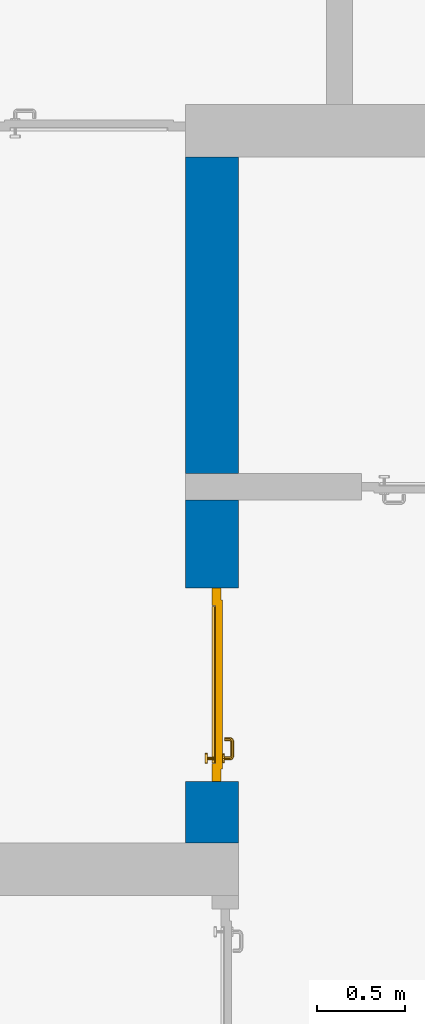
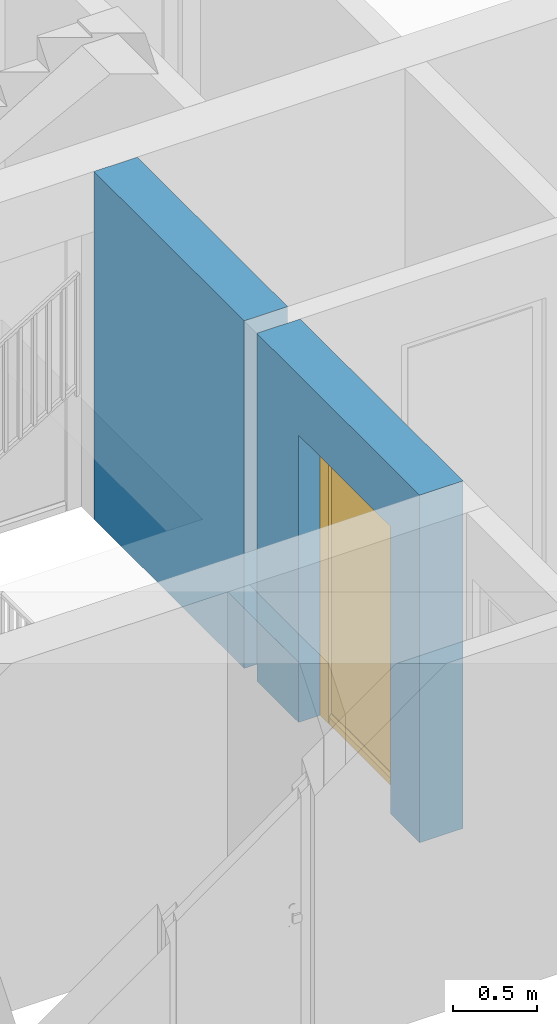
# One storey, part 12 of 48: 1 door, 1 wall, 1 opening.
"""IFC4 building model written with IfcOpenShell, lengths in metres."""

from ifc_helpers import new_model, entity, si_unit, converted_unit, derived_unit, direction, frame, origin_with_axes, place, context, subcontext, project, spatial, polygons, source, transform, mapped, material, type_object, element, fill, save


model = new_model("IFC4")

# Units and contexts
model_context = context("Model", 3, precision=1e-05, world=origin_with_axes(), true_north=direction((0.0, 1.0)))
body_context = subcontext(model_context, "Body", "Model", "MODEL_VIEW")
ifc_project = project(units=[si_unit("LENGTHUNIT", "METRE"), si_unit("AREAUNIT", "SQUARE_METRE"), si_unit("VOLUMEUNIT", "CUBIC_METRE"), converted_unit("PLANEANGLEUNIT", "DEGREE", entity("IfcPlaneAngleMeasure", 0.0174532925199), si_unit("PLANEANGLEUNIT", "RADIAN"), dimensions=[0, 0, 0, 0, 0, 0, 0]), converted_unit("TIMEUNIT", "Year", entity("IfcTimeMeasure", 31556926.0), si_unit("TIMEUNIT", "SECOND"), dimensions=[0, 0, 1, 0, 0, 0, 0]), si_unit("MASSUNIT", "GRAM", prefix="KILO"), si_unit("THERMODYNAMICTEMPERATUREUNIT", "DEGREE_CELSIUS"), si_unit("LUMINOUSINTENSITYUNIT", "LUMEN"), si_unit("ENERGYUNIT", "JOULE", prefix="MEGA"), derived_unit("THERMALCONDUCTANCEUNIT", [(si_unit("POWERUNIT", "WATT"), 1), (si_unit("LENGTHUNIT", "METRE"), -1), (si_unit("THERMODYNAMICTEMPERATUREUNIT", "KELVIN"), -1)]), derived_unit("SPECIFICHEATCAPACITYUNIT", [(si_unit("ENERGYUNIT", "JOULE"), 1), (si_unit("MASSUNIT", "GRAM", prefix="KILO"), -1), (si_unit("THERMODYNAMICTEMPERATUREUNIT", "KELVIN"), -1)]), derived_unit("MASSDENSITYUNIT", [(si_unit("MASSUNIT", "GRAM", prefix="KILO"), 1), (si_unit("VOLUMEUNIT", "CUBIC_METRE"), -1)])], contexts=[model_context])

# Site, building, storey
site_placement = place(None, origin_with_axes())
site = spatial("IfcSite", under=ifc_project, at=site_placement, CompositionType="ELEMENT")
building_placement = place(site_placement, origin_with_axes())
building = spatial("IfcBuilding", under=site, at=building_placement, CompositionType="ELEMENT")
storey_placement = place(building_placement, frame((0.0, 0.0, 3.4), z_axis=(0.0, 0.0, 1.0), x_axis=(1.0, 0.0, 0.0)))
storey = spatial("IfcBuildingStorey", under=building, at=storey_placement, Name="1. Geschoss", CompositionType="ELEMENT", Elevation=3.4)

# Wall, opening, door
ifc_material = material()
wall_type = type_object("IfcWallType", Name="300", PredefinedType="NOTDEFINED")
wall_placement = place(storey_placement, frame((2.8378006196, -2.52881223104, 0.0), z_axis=(0.0, 0.0, 1.0), x_axis=(0.0, 1.0, 0.0)))
wall = element("IfcWall", 1, at=wall_placement, inside=storey, type_object=wall_type, material=ifc_material, Name="Wand-001", PredefinedType="NOTDEFINED", context=body_context, shape_type="Tessellation", body=[
    polygons([(3.9, 0.3, 0.0), (3.9, 0.3, 2.54), (3.9, 0.0, 2.54), (3.9, 0.0, 0.0), (2.1, 0.3, 0.0), (2.1, 0.3, 2.54), (2.1, 0.0, 2.54), (2.1, 0.0, 0.0)], [[[1, 2, 3, 4]], [[5, 6, 2, 1]], [[6, 7, 3, 2]], [[4, 3, 7, 8]], [[5, 1, 4, 8]], [[8, 7, 6, 5]]], closed=True),
    polygons([(0.35, 0.0, 0.0), (0.35, 0.0, 2.1), (1.45, 0.0, 2.1), (1.45, 0.0, 0.0), (1.95, 0.0, 0.0), (1.95, 0.0, 2.54), (0.0, 0.0, 2.54), (0.0, 0.0, 0.0), (0.35, 0.15, 0.0), (0.35, 0.3, 0.0), (0.35, 0.3, 2.1), (1.45, 0.3, 2.1), (1.45, 0.15, 0.0), (1.45, 0.3, 0.0), (1.95, 0.3, 0.0), (1.95, 0.3, 2.54), (0.0, 0.3, 2.54), (0.0, 0.3, 0.0)], [[[1, 2, 3, 4, 5, 6, 7, 8]], [[2, 1, 9, 10, 11]], [[3, 2, 11, 12]], [[13, 4, 3, 12, 14]], [[4, 13, 14, 15, 5]], [[6, 5, 15, 16]], [[6, 16, 17, 7]], [[17, 18, 8, 7]], [[9, 1, 8, 18, 10]], [[15, 14, 12, 11, 10, 18, 17, 16]]], closed=True),
])
opening_placement = place(wall_placement, frame((0.9, 0.0, 0.0), z_axis=(0.0, 0.0, 1.0), x_axis=(1.0, 0.0, 0.0)))
opening = element("IfcOpeningElement", 2, at=opening_placement, cuts=wall, context=body_context, identifier="Reference", shape_type="Tessellation", body=[
    polygons([(-0.55, 0.15, 0.0), (-0.55, 0.15, 2.1), (-0.55, 0.301, 2.1), (-0.55, 0.301, 0.0), (-0.55, -0.001, 0.0), (-0.55, -0.001, 2.1), (0.55, 0.15, 2.1), (0.55, 0.301, 2.1), (0.55, -0.001, 2.1), (0.55, 0.301, 0.0), (0.55, 0.15, 0.0), (0.55, -0.001, 0.0)], [[[1, 2, 3, 4]], [[2, 1, 5, 6]], [[7, 8, 3, 2, 6, 9]], [[8, 10, 4, 3]], [[1, 4, 10, 11, 12, 5]], [[6, 5, 12, 9]], [[7, 11, 10, 8]], [[11, 7, 9, 12]]], closed=True),
])
door_type = type_object("IfcDoorType", Name="Eingang 01 1-Fl 26", OperationType="SINGLE_SWING_LEFT", PredefinedType="DOOR")
shared_shape = source(origin_with_axes(), body_context, "Body", "Tessellation", [
    polygons([(-0.55, -0.05, 0.0), (-0.55, -0.05, 2.1), (-0.55, -0.03, 2.1), (-0.55, -0.03, 0.0), (-0.45, -0.05, 0.0), (-0.45, -0.05, 2.0), (-0.1301, -0.05, 2.0), (-0.0001, -0.05, 2.0), (0.45, -0.05, 2.0), (0.45, -0.05, 0.0), (0.55, -0.05, 0.0), (0.55, -0.05, 2.1), (0.55, -0.03, 2.1), (0.55, -0.03, 0.0), (0.45, -0.03, 0.0), (0.45, -0.03, 2.0), (-0.0001, -0.03, 2.0), (-0.1301, -0.03, 2.0), (-0.45, -0.03, 2.0), (-0.45, -0.03, 0.0)], [[[1, 2, 3, 4]], [[1, 5, 6, 7, 8, 9, 10, 11, 12, 2]], [[2, 12, 13, 3]], [[4, 3, 13, 14, 15, 16, 17, 18, 19, 20]], [[5, 1, 4, 20]], [[6, 5, 20, 19]], [[7, 6, 19, 18]], [[8, 7, 18, 17]], [[9, 8, 17, 16]], [[10, 9, 16, 15]], [[11, 10, 15, 14]], [[12, 11, 14, 13]]], closed=True),
    polygons([(-0.55, -0.03, 0.0), (-0.55, -0.03, 2.1), (-0.55, 0.0, 2.1), (-0.55, 0.0, 0.0), (-0.48, -0.03, 0.0), (-0.48, -0.03, 2.03), (-0.1001, -0.03, 2.03), (-0.0301, -0.03, 2.03), (0.48, -0.03, 2.03), (0.48, -0.03, 0.0), (0.55, -0.03, 0.0), (0.55, -0.03, 2.1), (0.55, 0.0, 2.1), (0.55, 0.0, 0.0), (0.48, 0.0, 0.0), (0.48, 0.0, 2.03), (-0.0301, 0.0, 2.03), (-0.1001, 0.0, 2.03), (-0.48, 0.0, 2.03), (-0.48, 0.0, 0.0)], [[[1, 2, 3, 4]], [[1, 5, 6, 7, 8, 9, 10, 11, 12, 2]], [[2, 12, 13, 3]], [[4, 3, 13, 14, 15, 16, 17, 18, 19, 20]], [[5, 1, 4, 20]], [[6, 5, 20, 19]], [[7, 6, 19, 18]], [[8, 7, 18, 17]], [[9, 8, 17, 16]], [[10, 9, 16, 15]], [[11, 10, 15, 14]], [[12, 11, 14, 13]]], closed=True),
    polygons([(-0.48, 0.01, 0.0), (-0.48, 0.01, 2.03), (0.48, 0.01, 2.03), (0.48, 0.01, 0.0), (-0.48, -0.03, 0.0), (-0.48, -0.03, 2.03), (0.48, -0.03, 2.03), (0.48, -0.03, 0.0)], [[[1, 2, 3, 4]], [[1, 5, 6, 2]], [[2, 6, 7, 3]], [[3, 7, 8, 4]], [[4, 8, 5, 1]], [[8, 7, 6, 5]]], closed=True),
    polygons([(-0.445, -0.05, 0.0), (0.445, -0.05, 0.0), (0.445, -0.05, 0.05), (-0.445, -0.05, 0.05), (-0.445, -0.03, 0.0), (0.445, -0.03, 0.0), (0.445, -0.03, 0.07), (0.445, -0.035, 0.07), (-0.445, -0.035, 0.07), (-0.445, -0.03, 0.07)], [[[1, 2, 3, 4]], [[5, 6, 2, 1]], [[2, 6, 7, 8, 3]], [[4, 3, 8, 9]], [[1, 4, 9, 10, 5]], [[10, 7, 6, 5]], [[9, 8, 7, 10]]], closed=True),
    polygons([(0.4335, 0.02, 1.0733826859), (0.42, 0.02, 1.077), (0.42, 0.0199, 1.077), (0.4335, 0.0199, 1.0733826859), (0.443382685902, 0.02, 1.0635), (0.447, 0.02, 1.05), (0.443382685902, 0.02, 1.0365), (0.4335, 0.02, 1.0266173141), (0.42, 0.02, 1.023), (0.4065, 0.02, 1.0266173141), (0.396617314098, 0.02, 1.0365), (0.393, 0.02, 1.05), (0.396617314098, 0.02, 1.0635), (0.4065, 0.02, 1.0733826859), (0.4065, 0.0199, 1.0733826859), (0.42, 0.0101, 1.077), (0.4335, 0.0101, 1.0733826859), (0.443382685902, 0.0199, 1.0635), (0.447, 0.0199, 1.05), (0.443382685902, 0.0199, 1.0365), (0.4335, 0.0199, 1.0266173141), (0.42, 0.0199, 1.023), (0.4065, 0.0199, 1.0266173141), (0.396617314098, 0.0199, 1.0365), (0.393, 0.0199, 1.05), (0.396617314098, 0.0199, 1.0635), (0.4065, 0.0101, 1.0733826859), (0.42, 0.01, 1.077), (0.4335, 0.01, 1.0733826859), (0.443382685902, 0.0101, 1.0635), (0.447, 0.0101, 1.05), (0.443382685902, 0.0101, 1.0365), (0.4335, 0.0101, 1.0266173141), (0.42, 0.0101, 1.023), (0.4065, 0.0101, 1.0266173141), (0.396617314098, 0.0101, 1.0365), (0.393, 0.0101, 1.05), (0.396617314098, 0.0101, 1.0635), (0.4065, 0.01, 1.0733826859), (0.396617314098, 0.01, 1.0635), (0.393, 0.01, 1.05), (0.396617314098, 0.01, 1.0365), (0.4065, 0.01, 1.0266173141), (0.42, 0.01, 1.023), (0.4335, 0.01, 1.0266173141), (0.443382685902, 0.01, 1.0365), (0.447, 0.01, 1.05), (0.443382685902, 0.01, 1.0635)], [[[1, 2, 3, 4]], [[2, 1, 5, 6, 7, 8, 9, 10, 11, 12, 13, 14]], [[2, 14, 15, 3]], [[4, 3, 16, 17]], [[5, 1, 4, 18]], [[6, 5, 18, 19]], [[7, 6, 19, 20]], [[8, 7, 20, 21]], [[9, 8, 21, 22]], [[10, 9, 22, 23]], [[11, 10, 23, 24]], [[12, 11, 24, 25]], [[13, 12, 25, 26]], [[14, 13, 26, 15]], [[3, 15, 27, 16]], [[17, 16, 28, 29]], [[18, 4, 17, 30]], [[19, 18, 30, 31]], [[20, 19, 31, 32]], [[21, 20, 32, 33]], [[22, 21, 33, 34]], [[23, 22, 34, 35]], [[24, 23, 35, 36]], [[25, 24, 36, 37]], [[26, 25, 37, 38]], [[15, 26, 38, 27]], [[16, 27, 39, 28]], [[28, 39, 40, 41, 42, 43, 44, 45, 46, 47, 48, 29]], [[30, 17, 29, 48]], [[31, 30, 48, 47]], [[32, 31, 47, 46]], [[33, 32, 46, 45]], [[34, 33, 45, 44]], [[35, 34, 44, 43]], [[36, 35, 43, 42]], [[37, 36, 42, 41]], [[38, 37, 41, 40]], [[27, 38, 40, 39]]], closed=True),
    polygons([(0.412532169224, 0.019, 0.959692280177), (0.413279754556, 0.019, 0.961639806549), (0.40705, 0.019, 0.972430057958), (0.397569942042, 0.019, 0.96295), (0.415, 0.019, 0.952886751346), (0.415, 0.019, 0.9544), (0.412532169224, 0.02, 0.959692280177), (0.413279754556, 0.02, 0.961639806549), (0.414624817685, 0.02, 0.965143815798), (0.414624817685, 0.019, 0.965143815798), (0.42, 0.019, 0.967425445323), (0.42, 0.019, 0.9759), (0.407, 0.019, 0.972516660498), (0.397483339502, 0.019, 0.963), (0.415, 0.019, 0.95), (0.3941, 0.019, 0.95), (0.415, 0.019, 0.947113248654), (0.415, 0.019, 0.941339745962), (0.415, 0.019, 0.9375), (0.415, 0.02, 0.9375), (0.415, 0.02, 0.941339745962), (0.415, 0.02, 0.947113248654), (0.415, 0.02, 0.95), (0.415, 0.02, 0.952886751346), (0.415, 0.02, 0.9544), (0.396703916638, 0.02, 0.96345), (0.40655, 0.02, 0.973296083362), (0.42, 0.02, 0.9769), (0.42, 0.02, 0.967425445323), (0.425375182315, 0.019, 0.965143815798), (0.426720245444, 0.019, 0.961639806549), (0.43295, 0.019, 0.972430057958), (0.42, 0.019, 0.976), (0.407, 0.0189, 0.972516660498), (0.397483339502, 0.0189, 0.963), (0.394, 0.019, 0.95), (0.397569942042, 0.019, 0.93705), (0.40705, 0.019, 0.927569942042), (0.42, 0.019, 0.9241), (0.42, 0.019, 0.9325), (0.416464466094, 0.019, 0.933964466094), (0.416464466094, 0.02, 0.933964466094), (0.42, 0.02, 0.9231), (0.40655, 0.02, 0.926703916638), (0.42, 0.02, 0.9325), (0.396703916638, 0.02, 0.93655), (0.3931, 0.02, 0.95), (0.396617314098, 0.02, 0.9635), (0.4065, 0.02, 0.973382685902), (0.42, 0.02, 0.977), (0.425375182315, 0.02, 0.965143815798), (0.43345, 0.02, 0.973296083362), (0.426720245444, 0.02, 0.961639806549), (0.427467830776, 0.02, 0.959692280177), (0.427467830776, 0.019, 0.959692280177), (0.425, 0.019, 0.9544), (0.425, 0.019, 0.952886751346), (0.442430057958, 0.019, 0.96295), (0.433, 0.019, 0.972516660498), (0.42, 0.0189, 0.976), (0.407, 0.0101, 0.972516660498), (0.397483339502, 0.0101, 0.963), (0.394, 0.0189, 0.95), (0.397483339502, 0.019, 0.937), (0.407, 0.019, 0.927483339502), (0.42, 0.019, 0.924), (0.43295, 0.019, 0.927569942042), (0.425, 0.019, 0.941339745962), (0.425, 0.019, 0.9375), (0.423535533906, 0.019, 0.933964466094), (0.42, 0.02, 0.923), (0.4065, 0.02, 0.926617314098), (0.43345, 0.02, 0.926703916638), (0.423535533906, 0.02, 0.933964466094), (0.425, 0.02, 0.9375), (0.425, 0.02, 0.941339745962), (0.396617314098, 0.02, 0.9365), (0.393, 0.02, 0.95), (0.396617314098, 0.0199, 0.9635), (0.4065, 0.0199, 0.973382685902), (0.42, 0.0199, 0.977), (0.4335, 0.02, 0.973382685902), (0.443296083362, 0.02, 0.96345), (0.425, 0.02, 0.952886751346), (0.425, 0.02, 0.9544), (0.425, 0.02, 0.95), (0.425, 0.02, 0.947113248654), (0.425, 0.019, 0.947113248654), (0.425, 0.019, 0.95), (0.4459, 0.019, 0.95), (0.442516660498, 0.019, 0.963), (0.433, 0.0189, 0.972516660498), (0.42, 0.0101, 0.976), (0.407, 0.01, 0.972516660498), (0.397483339502, 0.01, 0.963), (0.394, 0.0101, 0.95), (0.397483339502, 0.0189, 0.937), (0.407, 0.0189, 0.927483339502), (0.42, 0.0189, 0.924), (0.433, 0.019, 0.927483339502), (0.442430057958, 0.019, 0.93705), (0.42, 0.0199, 0.923), (0.4065, 0.0199, 0.926617314098), (0.4335, 0.02, 0.926617314098), (0.443296083362, 0.02, 0.93655), (0.396617314098, 0.0199, 0.9365), (0.393, 0.0199, 0.95), (0.396617314098, 0.0101, 0.9635), (0.4065, 0.0101, 0.973382685902), (0.42, 0.0101, 0.977), (0.4335, 0.0199, 0.973382685902), (0.443382685902, 0.02, 0.9635), (0.4469, 0.02, 0.95), (0.446, 0.019, 0.95), (0.442516660498, 0.0189, 0.963), (0.433, 0.0101, 0.972516660498), (0.42, 0.01, 0.976), (0.40695, 0.01, 0.972603263039), (0.397396736961, 0.01, 0.96305), (0.394, 0.01, 0.95), (0.397483339502, 0.0101, 0.937), (0.407, 0.0101, 0.927483339502), (0.42, 0.0101, 0.924), (0.433, 0.0189, 0.927483339502), (0.442516660498, 0.019, 0.937), (0.42, 0.0101, 0.923), (0.4065, 0.0101, 0.926617314098), (0.4335, 0.0199, 0.926617314098), (0.443382685902, 0.02, 0.9365), (0.396617314098, 0.0101, 0.9365), (0.393, 0.0101, 0.95), (0.396617314098, 0.01, 0.9635), (0.4065, 0.01, 0.973382685902), (0.42, 0.01, 0.977), (0.4335, 0.0101, 0.973382685902), (0.443382685902, 0.0199, 0.9635), (0.447, 0.02, 0.95), (0.446, 0.0189, 0.95), (0.442516660498, 0.0101, 0.963), (0.433, 0.01, 0.972516660498), (0.42, 0.01, 0.9761), (0.40655, 0.01, 0.973296083362), (0.396703916638, 0.01, 0.96345), (0.3939, 0.01, 0.95), (0.397483339502, 0.01, 0.937), (0.407, 0.01, 0.927483339502), (0.42, 0.01, 0.924), (0.433, 0.0101, 0.927483339502), (0.442516660498, 0.0189, 0.937), (0.42, 0.01, 0.923), (0.4065, 0.01, 0.926617314098), (0.4335, 0.0101, 0.926617314098), (0.443382685902, 0.0199, 0.9365), (0.396617314098, 0.01, 0.9365), (0.393, 0.01, 0.95), (0.42, 0.01, 0.9769), (0.4335, 0.01, 0.973382685902), (0.443382685902, 0.0101, 0.9635), (0.447, 0.0199, 0.95), (0.446, 0.0101, 0.95), (0.442516660498, 0.01, 0.963), (0.43305, 0.01, 0.972603263039), (0.3931, 0.01, 0.95), (0.397396736961, 0.01, 0.93695), (0.40695, 0.01, 0.927396736961), (0.42, 0.01, 0.9239), (0.433, 0.01, 0.927483339502), (0.442516660498, 0.0101, 0.937), (0.42, 0.01, 0.9231), (0.40655, 0.01, 0.926703916638), (0.4335, 0.01, 0.926617314098), (0.443382685902, 0.0101, 0.9365), (0.396703916638, 0.01, 0.93655), (0.43345, 0.01, 0.973296083362), (0.443382685902, 0.01, 0.9635), (0.447, 0.0101, 0.95), (0.446, 0.01, 0.95), (0.442603263039, 0.01, 0.96305), (0.43305, 0.01, 0.927396736961), (0.442516660498, 0.01, 0.937), (0.43345, 0.01, 0.926703916638), (0.443382685902, 0.01, 0.9365), (0.443296083362, 0.01, 0.96345), (0.447, 0.01, 0.95), (0.4461, 0.01, 0.95), (0.442603263039, 0.01, 0.93695), (0.443296083362, 0.01, 0.93655), (0.4469, 0.01, 0.95)], [[[1, 2, 3, 4, 5, 6]], [[1, 7, 8, 9, 10, 2]], [[10, 11, 12, 3, 2]], [[4, 3, 13, 14]], [[15, 5, 4, 16]], [[6, 5, 15, 17, 18, 19, 20, 21, 22, 23, 24, 25]], [[6, 25, 7, 1]], [[7, 25, 24, 26, 27, 8]], [[9, 8, 27, 28, 29]], [[10, 9, 29, 11]], [[30, 31, 32, 12, 11]], [[3, 12, 33, 13]], [[14, 13, 34, 35]], [[16, 4, 14, 36]], [[17, 15, 16, 37]], [[18, 17, 37, 38]], [[38, 39, 40, 41, 19, 18]], [[19, 41, 42, 20]], [[43, 44, 21, 20, 42, 45]], [[22, 21, 44, 46]], [[23, 22, 46, 47]], [[24, 23, 47, 26]], [[48, 49, 27, 26]], [[49, 50, 28, 27]], [[51, 29, 28, 52, 53]], [[11, 29, 51, 30]], [[30, 51, 53, 54, 55, 31]], [[55, 56, 57, 58, 32, 31]], [[12, 32, 59, 33]], [[13, 33, 60, 34]], [[35, 34, 61, 62]], [[36, 14, 35, 63]], [[37, 16, 36, 64]], [[38, 37, 64, 65]], [[39, 38, 65, 66]], [[39, 67, 68, 69, 70, 40]], [[41, 40, 45, 42]], [[71, 72, 44, 43]], [[73, 43, 45, 74, 75, 76]], [[72, 77, 46, 44]], [[77, 78, 47, 46]], [[78, 48, 26, 47]], [[79, 80, 49, 48]], [[80, 81, 50, 49]], [[50, 82, 52, 28]], [[54, 53, 52, 83, 84, 85]], [[55, 54, 85, 56]], [[85, 84, 86, 87, 76, 75, 69, 68, 88, 89, 57, 56]], [[57, 89, 90, 58]], [[32, 58, 91, 59]], [[33, 59, 92, 60]], [[34, 60, 93, 61]], [[62, 61, 94, 95]], [[63, 35, 62, 96]], [[64, 36, 63, 97]], [[65, 64, 97, 98]], [[66, 65, 98, 99]], [[67, 39, 66, 100]], [[88, 68, 67, 101]], [[70, 69, 75, 74]], [[40, 70, 74, 45]], [[102, 103, 72, 71]], [[104, 71, 43, 73]], [[76, 87, 105, 73]], [[103, 106, 77, 72]], [[106, 107, 78, 77]], [[107, 79, 48, 78]], [[108, 109, 80, 79]], [[109, 110, 81, 80]], [[81, 111, 82, 50]], [[82, 112, 83, 52]], [[86, 84, 83, 113]], [[87, 86, 113, 105]], [[89, 88, 101, 90]], [[58, 90, 114, 91]], [[59, 91, 115, 92]], [[60, 92, 116, 93]], [[61, 93, 117, 94]], [[95, 94, 118, 119]], [[96, 62, 95, 120]], [[97, 63, 96, 121]], [[98, 97, 121, 122]], [[99, 98, 122, 123]], [[100, 66, 99, 124]], [[101, 67, 100, 125]], [[126, 127, 103, 102]], [[128, 102, 71, 104]], [[129, 104, 73, 105]], [[127, 130, 106, 103]], [[130, 131, 107, 106]], [[131, 108, 79, 107]], [[132, 133, 109, 108]], [[133, 134, 110, 109]], [[110, 135, 111, 81]], [[111, 136, 112, 82]], [[112, 137, 113, 83]], [[137, 129, 105, 113]], [[90, 101, 125, 114]], [[91, 114, 138, 115]], [[92, 115, 139, 116]], [[93, 116, 140, 117]], [[94, 117, 141, 118]], [[119, 118, 142, 143]], [[120, 95, 119, 144]], [[121, 96, 120, 145]], [[122, 121, 145, 146]], [[123, 122, 146, 147]], [[124, 99, 123, 148]], [[125, 100, 124, 149]], [[150, 151, 127, 126]], [[152, 126, 102, 128]], [[153, 128, 104, 129]], [[151, 154, 130, 127]], [[154, 155, 131, 130]], [[155, 132, 108, 131]], [[143, 142, 133, 132]], [[142, 156, 134, 133]], [[134, 157, 135, 110]], [[135, 158, 136, 111]], [[136, 159, 137, 112]], [[159, 153, 129, 137]], [[114, 125, 149, 138]], [[115, 138, 160, 139]], [[116, 139, 161, 140]], [[117, 140, 162, 141]], [[118, 141, 156, 142]], [[144, 119, 143, 163]], [[145, 120, 144, 164]], [[146, 145, 164, 165]], [[147, 146, 165, 166]], [[148, 123, 147, 167]], [[149, 124, 148, 168]], [[169, 170, 151, 150]], [[171, 150, 126, 152]], [[172, 152, 128, 153]], [[170, 173, 154, 151]], [[173, 163, 155, 154]], [[163, 143, 132, 155]], [[156, 174, 157, 134]], [[157, 175, 158, 135]], [[158, 176, 159, 136]], [[176, 172, 153, 159]], [[138, 149, 168, 160]], [[139, 160, 177, 161]], [[140, 161, 178, 162]], [[141, 162, 174, 156]], [[164, 144, 163, 173]], [[165, 164, 173, 170]], [[166, 165, 170, 169]], [[167, 147, 166, 179]], [[168, 148, 167, 180]], [[181, 169, 150, 171]], [[182, 171, 152, 172]], [[174, 183, 175, 157]], [[175, 184, 176, 158]], [[184, 182, 172, 176]], [[160, 168, 180, 177]], [[161, 177, 185, 178]], [[162, 178, 183, 174]], [[179, 166, 169, 181]], [[180, 167, 179, 186]], [[187, 181, 171, 182]], [[183, 188, 184, 175]], [[188, 187, 182, 184]], [[177, 180, 186, 185]], [[178, 185, 188, 183]], [[186, 179, 181, 187]], [[185, 186, 187, 188]]], closed=True),
    polygons([(0.43, 0.02, 1.05), (0.427071067812, 0.02, 1.04292893219), (0.427071067812, 0.050696439392, 1.04292893219), (0.43, 0.0509849140336, 1.05), (0.42, 0.02, 1.04), (0.42, 0.05, 1.04), (0.425518993221, 0.0584992452783, 1.04292893219), (0.428277987014, 0.0596420579258, 1.05), (0.427071067812, 0.02, 1.05707106781), (0.427071067812, 0.050696439392, 1.05707106781), (0.412928932188, 0.02, 1.04292893219), (0.412928932188, 0.049303560608, 1.04292893219), (0.418858192988, 0.0557402514855, 1.04), (0.420704557509, 0.0657045575088, 1.04292893219), (0.422816199938, 0.0678161999379, 1.05), (0.425518993221, 0.0584992452783, 1.05707106781), (0.42, 0.02, 1.06), (0.42, 0.05, 1.06), (0.41, 0.02, 1.05), (0.41, 0.0490150859664, 1.05), (0.412197392755, 0.0529812576926, 1.04292893219), (0.415606601718, 0.0606066017178, 1.04), (0.413499245278, 0.0705189932208, 1.04292893219), (0.414642057926, 0.0732779870137, 1.05), (0.420704557509, 0.0657045575088, 1.05707106781), (0.418858192988, 0.0557402514855, 1.06), (0.412928932188, 0.02, 1.05707106781), (0.412928932188, 0.049303560608, 1.05707106781), (0.409438398962, 0.0518384450452, 1.05), (0.410508645927, 0.0555086459268, 1.04292893219), (0.410740251485, 0.0638581929877, 1.04), (0.405696439392, 0.0720710678119, 1.04292893219), (0.405984914034, 0.075, 1.05), (0.413499245278, 0.0705189932208, 1.05707106781), (0.415606601718, 0.0606066017178, 1.06), (0.412197392755, 0.0529812576926, 1.05707106781), (0.408397003498, 0.0533970034977, 1.05), (0.407981257693, 0.0571973927545, 1.04292893219), (0.405, 0.065, 1.04), (0.324303560608, 0.0720710678119, 1.04292893219), (0.324015085966, 0.075, 1.05), (0.405696439392, 0.0720710678119, 1.05707106781), (0.410740251485, 0.0638581929877, 1.06), (0.410508645927, 0.0555086459268, 1.05707106781), (0.406838445045, 0.0544383989617, 1.05), (0.404303560608, 0.0579289321881, 1.04292893219), (0.325, 0.065, 1.04), (0.316500754722, 0.0705189932208, 1.04292893219), (0.315357942074, 0.0732779870137, 1.05), (0.324303560608, 0.0720710678119, 1.05707106781), (0.405, 0.065, 1.06), (0.407981257693, 0.0571973927545, 1.05707106781), (0.404015085966, 0.055, 1.05), (0.325696439392, 0.0579289321881, 1.04292893219), (0.319259748515, 0.0638581929877, 1.04), (0.309295442491, 0.0657045575088, 1.04292893219), (0.307183800062, 0.0678161999379, 1.05), (0.316500754722, 0.0705189932208, 1.05707106781), (0.325, 0.065, 1.06), (0.404303560608, 0.0579289321881, 1.05707106781), (0.325984914034, 0.055, 1.05), (0.322018742307, 0.0571973927545, 1.04292893219), (0.314393398282, 0.0606066017178, 1.04), (0.304481006779, 0.0584992452783, 1.04292893219), (0.301722012986, 0.0596420579258, 1.05), (0.309295442491, 0.0657045575088, 1.05707106781), (0.319259748515, 0.0638581929877, 1.06), (0.325696439392, 0.0579289321881, 1.05707106781), (0.323161554955, 0.0544383989617, 1.05), (0.319491354073, 0.0555086459268, 1.04292893219), (0.311141807012, 0.0557402514855, 1.04), (0.302928932188, 0.050696439392, 1.04292893219), (0.3, 0.0509849140336, 1.05), (0.304481006779, 0.0584992452783, 1.05707106781), (0.314393398282, 0.0606066017178, 1.06), (0.322018742307, 0.0571973927545, 1.05707106781), (0.321602996502, 0.0533970034977, 1.05), (0.317802607245, 0.0529812576926, 1.04292893219), (0.31, 0.05, 1.04), (0.302928932188, 0.02, 1.04292893219), (0.3, 0.02, 1.05), (0.302928932188, 0.050696439392, 1.05707106781), (0.311141807012, 0.0557402514855, 1.06), (0.319491354073, 0.0555086459268, 1.05707106781), (0.320561601038, 0.0518384450452, 1.05), (0.317071067812, 0.049303560608, 1.04292893219), (0.31, 0.02, 1.04), (0.317071067812, 0.02, 1.04292893219), (0.32, 0.02, 1.05), (0.317071067812, 0.02, 1.05707106781), (0.31, 0.02, 1.06), (0.302928932188, 0.02, 1.05707106781), (0.31, 0.05, 1.06), (0.317802607245, 0.0529812576926, 1.05707106781), (0.32, 0.0490150859664, 1.05), (0.317071067812, 0.049303560608, 1.05707106781)], [[[1, 2, 3, 4]], [[2, 5, 6, 3]], [[4, 3, 7, 8]], [[9, 1, 4, 10]], [[5, 11, 12, 6]], [[3, 6, 13, 7]], [[8, 7, 14, 15]], [[10, 4, 8, 16]], [[17, 9, 10, 18]], [[11, 19, 20, 12]], [[6, 12, 21, 13]], [[7, 13, 22, 14]], [[15, 14, 23, 24]], [[16, 8, 15, 25]], [[18, 10, 16, 26]], [[27, 17, 18, 28]], [[19, 27, 28, 20]], [[12, 20, 29, 21]], [[13, 21, 30, 22]], [[14, 22, 31, 23]], [[24, 23, 32, 33]], [[25, 15, 24, 34]], [[26, 16, 25, 35]], [[28, 18, 26, 36]], [[20, 28, 36, 29]], [[21, 29, 37, 30]], [[22, 30, 38, 31]], [[23, 31, 39, 32]], [[33, 32, 40, 41]], [[34, 24, 33, 42]], [[35, 25, 34, 43]], [[36, 26, 35, 44]], [[29, 36, 44, 37]], [[30, 37, 45, 38]], [[31, 38, 46, 39]], [[32, 39, 47, 40]], [[41, 40, 48, 49]], [[42, 33, 41, 50]], [[43, 34, 42, 51]], [[44, 35, 43, 52]], [[37, 44, 52, 45]], [[38, 45, 53, 46]], [[39, 46, 54, 47]], [[40, 47, 55, 48]], [[49, 48, 56, 57]], [[50, 41, 49, 58]], [[51, 42, 50, 59]], [[52, 43, 51, 60]], [[45, 52, 60, 53]], [[46, 53, 61, 54]], [[47, 54, 62, 55]], [[48, 55, 63, 56]], [[57, 56, 64, 65]], [[58, 49, 57, 66]], [[59, 50, 58, 67]], [[60, 51, 59, 68]], [[53, 60, 68, 61]], [[54, 61, 69, 62]], [[55, 62, 70, 63]], [[56, 63, 71, 64]], [[65, 64, 72, 73]], [[66, 57, 65, 74]], [[67, 58, 66, 75]], [[68, 59, 67, 76]], [[61, 68, 76, 69]], [[62, 69, 77, 70]], [[63, 70, 78, 71]], [[64, 71, 79, 72]], [[73, 72, 80, 81]], [[74, 65, 73, 82]], [[75, 66, 74, 83]], [[76, 67, 75, 84]], [[69, 76, 84, 77]], [[70, 77, 85, 78]], [[71, 78, 86, 79]], [[72, 79, 87, 80]], [[81, 80, 87, 88, 89, 90, 91, 92]], [[82, 73, 81, 92]], [[83, 74, 82, 93]], [[84, 75, 83, 94]], [[77, 84, 94, 85]], [[78, 85, 95, 86]], [[79, 86, 88, 87]], [[86, 95, 89, 88]], [[95, 96, 90, 89]], [[96, 93, 91, 90]], [[93, 82, 92, 91]], [[94, 83, 93, 96]], [[85, 94, 96, 95]]], closed=False),
    polygons([(0.414696699141, -0.035, 1.04469669914), (0.4125, -0.035, 1.05), (0.414696699141, -0.035, 1.05530330086), (0.42, -0.035, 1.0575), (0.425303300859, -0.035, 1.05530330086), (0.4275, -0.035, 1.05), (0.425303300859, -0.035, 1.04469669914), (0.42, -0.035, 1.0425), (0.414696699141, -0.075, 1.04469669914), (0.4125, -0.075, 1.05), (0.414696699141, -0.075, 1.05530330086), (0.42, -0.075, 1.0575), (0.425303300859, -0.075, 1.05530330086), (0.4275, -0.075, 1.05), (0.425303300859, -0.075, 1.04469669914), (0.42, -0.075, 1.0425)], [[[1, 2, 3, 4, 5, 6, 7, 8]], [[1, 9, 10, 2]], [[2, 10, 11, 3]], [[3, 11, 12, 4]], [[4, 12, 13, 5]], [[5, 13, 14, 6]], [[6, 14, 15, 7]], [[7, 15, 16, 8]], [[8, 16, 9, 1]], [[9, 16, 15, 14, 13, 12, 11, 10]]], closed=True),
    polygons([(0.445, -0.03, 0.975), (0.445, -0.035, 0.975), (0.443096988313, -0.035, 0.965432914191), (0.443096988313, -0.03, 0.965432914191), (0.445, -0.03, 1.1), (0.445, -0.035, 1.1), (0.443096988313, -0.035, 1.10956708581), (0.43767766953, -0.035, 1.11767766953), (0.429567085809, -0.035, 1.12309698831), (0.42, -0.035, 1.125), (0.410432914191, -0.035, 1.12309698831), (0.40232233047, -0.035, 1.11767766953), (0.396903011687, -0.035, 1.10956708581), (0.395, -0.035, 1.1), (0.395, -0.035, 0.975), (0.396903011687, -0.035, 0.965432914191), (0.40232233047, -0.035, 0.95732233047), (0.410432914191, -0.035, 0.951903011687), (0.42, -0.035, 0.95), (0.429567085809, -0.035, 0.951903011687), (0.43767766953, -0.035, 0.95732233047), (0.43767766953, -0.03, 0.95732233047), (0.429567085809, -0.03, 0.951903011687), (0.42, -0.03, 0.95), (0.410432914191, -0.03, 0.951903011687), (0.40232233047, -0.03, 0.95732233047), (0.396903011687, -0.03, 0.965432914191), (0.395, -0.03, 0.975), (0.395, -0.03, 1.1), (0.396903011687, -0.03, 1.10956708581), (0.40232233047, -0.03, 1.11767766953), (0.410432914191, -0.03, 1.12309698831), (0.42, -0.03, 1.125), (0.429567085809, -0.03, 1.12309698831), (0.43767766953, -0.03, 1.11767766953), (0.443096988313, -0.03, 1.10956708581)], [[[1, 2, 3, 4]], [[5, 6, 2, 1]], [[2, 6, 7, 8, 9, 10, 11, 12, 13, 14, 15, 16, 17, 18, 19, 20, 21, 3]], [[4, 3, 21, 22]], [[1, 4, 22, 23, 24, 25, 26, 27, 28, 29, 30, 31, 32, 33, 34, 35, 36, 5]], [[36, 7, 6, 5]], [[35, 8, 7, 36]], [[34, 9, 8, 35]], [[33, 10, 9, 34]], [[32, 11, 10, 33]], [[31, 12, 11, 32]], [[30, 13, 12, 31]], [[29, 14, 13, 30]], [[28, 15, 14, 29]], [[27, 16, 15, 28]], [[26, 17, 16, 27]], [[25, 18, 17, 26]], [[24, 19, 18, 25]], [[23, 20, 19, 24]], [[22, 21, 20, 23]]], closed=True),
    polygons([(0.44, -0.075, 1.08), (0.44, -0.09, 1.08), (0.445, -0.09, 1.07866025404), (0.445, -0.075, 1.07866025404), (0.4, -0.075, 1.08), (0.4, -0.09, 1.08), (0.395, -0.09, 1.07866025404), (0.391339745962, -0.09, 1.075), (0.39, -0.09, 1.07), (0.39, -0.09, 1.03), (0.391339745962, -0.09, 1.025), (0.395, -0.09, 1.02133974596), (0.4, -0.09, 1.02), (0.44, -0.09, 1.02), (0.445, -0.09, 1.02133974596), (0.448660254038, -0.09, 1.025), (0.45, -0.09, 1.03), (0.45, -0.09, 1.07), (0.448660254038, -0.09, 1.075), (0.448660254038, -0.075, 1.075), (0.45, -0.075, 1.07), (0.45, -0.075, 1.03), (0.448660254038, -0.075, 1.025), (0.445, -0.075, 1.02133974596), (0.44, -0.075, 1.02), (0.4, -0.075, 1.02), (0.395, -0.075, 1.02133974596), (0.391339745962, -0.075, 1.025), (0.39, -0.075, 1.03), (0.39, -0.075, 1.07), (0.391339745962, -0.075, 1.075), (0.395, -0.075, 1.07866025404)], [[[1, 2, 3, 4]], [[5, 6, 2, 1]], [[2, 6, 7, 8, 9, 10, 11, 12, 13, 14, 15, 16, 17, 18, 19, 3]], [[4, 3, 19, 20]], [[1, 4, 20, 21, 22, 23, 24, 25, 26, 27, 28, 29, 30, 31, 32, 5]], [[32, 7, 6, 5]], [[31, 8, 7, 32]], [[30, 9, 8, 31]], [[29, 10, 9, 30]], [[28, 11, 10, 29]], [[27, 12, 11, 28]], [[26, 13, 12, 27]], [[25, 14, 13, 26]], [[24, 15, 14, 25]], [[23, 16, 15, 24]], [[22, 17, 16, 23]], [[21, 18, 17, 22]], [[20, 19, 18, 21]]], closed=True),
])
door_placement = place(opening_placement, frame((0.45, 0.0, 0.0), z_axis=(0.0, 0.0, 1.0), x_axis=(-1.0, 0.0, 0.0)))
door = element("IfcDoor", 3, at=door_placement, inside=storey, type_object=door_type, OverallHeight=2.1, OverallWidth=1.1, PredefinedType="DOOR", context=body_context, shape_type="MappedRepresentation", body=[
    mapped(shared_shape, transform((0.45, -0.1, 0.0))),
])
fill(opening, door)

save(model, "model.ifc")
